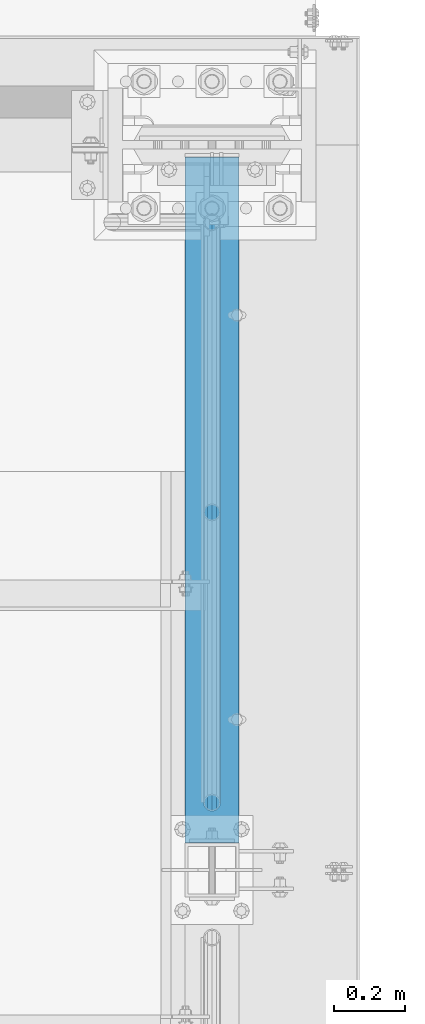
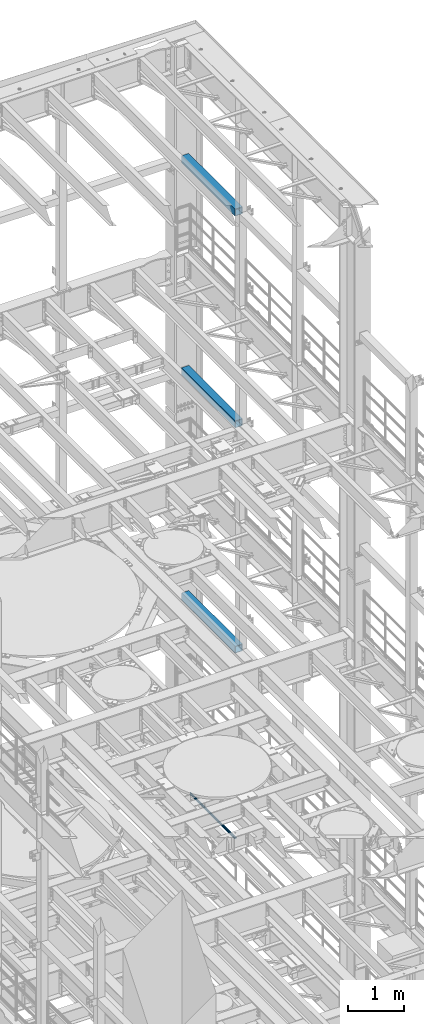
# One storey, part 1079 of 1876: 4 beams, 4 elements without a shape of their own.
"""IFC2X3 building model written with IfcOpenShell, lengths in millimetres."""

from ifc_helpers import new_model, si_unit, frame, origin_with_axes, place, context, subcontext, project, spatial, faceted_brep, material, type_object, element, aggregate, save


model = new_model("IFC2X3")

# Units and contexts
model_context = context("Model", 3, precision=1e-05, world=origin_with_axes())
body_context = subcontext(model_context, "Body", "Model", "MODEL_VIEW")
ifc_project = project(units=[si_unit("LENGTHUNIT", "METRE", prefix="MILLI"), si_unit("AREAUNIT", "SQUARE_METRE"), si_unit("VOLUMEUNIT", "CUBIC_METRE"), si_unit("MASSUNIT", "GRAM", prefix="KILO"), si_unit("TIMEUNIT", "SECOND"), si_unit("PLANEANGLEUNIT", "RADIAN"), si_unit("SOLIDANGLEUNIT", "STERADIAN"), si_unit("THERMODYNAMICTEMPERATUREUNIT", "DEGREE_CELSIUS"), si_unit("LUMINOUSINTENSITYUNIT", "LUMEN")], contexts=[model_context])

# Site, building, storey
site_placement = place(None, origin_with_axes())
site = spatial("IfcSite", under=ifc_project, at=site_placement, CompositionType="ELEMENT")
building_placement = place(site_placement, origin_with_axes())
building = spatial("IfcBuilding", under=site, at=building_placement, Name="Undefined", CompositionType="ELEMENT")
storey_placement = place(building_placement, origin_with_axes())
storey = spatial("IfcBuildingStorey", under=building, at=storey_placement, Name="Undefined", CompositionType="ELEMENT", Elevation=0.0)

# Assembly, beam
assembly_1_placement = place(storey_placement, origin_with_axes())
assembly_1 = element("IfcElementAssembly", 1, at=assembly_1_placement, inside=storey, Name="RAIL", AssemblyPlace="NOTDEFINED", PredefinedType="RIGID_FRAME")
ifc_material_1 = material()
beam_type_1 = type_object("IfcBeamType", Name="PIPE1-1/2SCH40", PredefinedType="NOTDEFINED")
beam_1_placement = place(assembly_1_placement, frame((7619.99999999998, 11848.7825, 6207.125), z_axis=(0.0, 0.0, -1.0), x_axis=(0.0, 1.0, 0.0)))
beam_1 = element("IfcBeam", 2, at=beam_1_placement, type_object=beam_type_1, material=ifc_material_1, Name="RAIL", ObjectType="PIPE1-1/2SCH40", context=body_context, shape_type="Brep", body=[
    faceted_brep([(24.1300000000001, -20.4469999999999, 0.0), (34.3535000000002, -17.7076214311803, 10.2235000000001), (1633.21617856882, -17.7076214311801, 10.2235000000001), (1630.4768, -20.4470000000001, 0.0), (41.8376214311802, -10.2235000000001, 17.7076214311819), (1640.7003, -10.2235000000001, 17.7076214311819), (44.5770000000002, 0.0, 20.4470000000001), (1650.9238, 0.0, 20.4470000000001), (41.8376214311802, 10.2235000000001, 17.7076214311819), (1661.1473, 10.2235000000001, 17.7076214311819), (34.3535000000002, 17.7076214311803, 10.2235000000001), (1668.63142143118, 17.7076214311801, 10.2235000000001), (24.1300000000001, 20.4469999999999, 0.0), (1671.3708, 20.4470000000001, 0.0), (13.9065000000001, 17.7076214311803, -10.2235000000001), (1668.63142143118, 17.7076214311801, -10.2235000000001), (6.42237856882002, 10.2235000000001, -17.7076214311819), (1661.1473, 10.2235000000001, -17.7076214311819), (3.68299999999999, 0.0, -20.4470000000001), (1650.9238, 0.0, -20.4470000000001), (6.42237856882002, -10.2235000000001, -17.7076214311819), (1640.7003, -10.2235000000001, -17.7076214311819), (13.9065000000001, -17.7076214311803, -10.2235000000001), (1633.21617856882, -17.7076214311801, -10.2235000000001), (24.1299999999854, -24.1299999999992, 0.0), (12.0650000000064, -20.8971929933177, -12.0649999999987), (1630.02660700668, -20.8971929933186, -12.0649999999987), (1626.7938, -24.1300000000001, 0.0), (3.23280700668147, -12.0650000000001, -20.8971929933177), (1638.8588, -12.0649999999996, -20.8971929933177), (-1.45519152283669e-11, 0.0, -24.130000000001), (1650.9238, 0.0, -24.130000000001), (3.23280700668147, 12.0650000000001, -20.8971929933177), (1662.9888, 12.0649999999996, -20.8971929933177), (12.0650000000064, 20.8971929933177, -12.0649999999987), (1671.82099299332, 20.8971929933186, -12.0649999999987), (24.1300000000047, 24.1299999999992, 0.0), (1675.0538, 24.1300000000001, 0.0), (36.1949999999997, 20.8971929933184, 12.0649999999987), (1671.82099299332, 20.8971929933186, 12.0649999999987), (45.0271929933187, 12.0650000000001, 20.8971929933177), (1662.9888, 12.0649999999996, 20.8971929933177), (48.2600000000002, 0.0, 24.130000000001), (1650.9238, 0.0, 24.130000000001), (45.0271929933187, -12.0650000000001, 20.8971929933177), (1638.8588, -12.0649999999996, 20.8971929933177), (36.1949999999997, -20.8971929933184, 12.0649999999987), (1630.02660700668, -20.8971929933186, 12.0649999999987)], [[[0, 1, 2, 3]], [[1, 4, 5, 2]], [[4, 6, 7, 5]], [[6, 8, 9, 7]], [[8, 10, 11, 9]], [[10, 12, 13, 11]], [[12, 14, 15, 13]], [[14, 16, 17, 15]], [[16, 18, 19, 17]], [[18, 20, 21, 19]], [[20, 22, 23, 21]], [[22, 0, 3, 23]], [[24, 25, 26, 27]], [[25, 28, 29, 26]], [[28, 30, 31, 29]], [[30, 32, 33, 31]], [[32, 34, 35, 33]], [[34, 36, 37, 35]], [[36, 38, 39, 37]], [[38, 40, 41, 39]], [[40, 42, 43, 41]], [[42, 44, 45, 43]], [[44, 46, 47, 45]], [[46, 24, 27, 47]], [[29, 31, 33, 35, 37, 39, 41, 43, 45, 47, 27, 26], [5, 7, 9, 11, 13, 15, 17, 19, 21, 23, 3, 2]], [[46, 44, 42, 40, 38, 36, 34, 32, 30, 28, 25, 24], [22, 20, 18, 16, 14, 12, 10, 8, 6, 4, 1, 0]]]),
])
aggregate(assembly_1, [beam_1])

assembly_2_placement = place(storey_placement, origin_with_axes())
assembly_2 = element("IfcElementAssembly", 3, at=assembly_2_placement, inside=storey, Name="BEAM", AssemblyPlace="NOTDEFINED", PredefinedType="RIGID_FRAME")
ifc_material_2 = material()
beam_type_2 = type_object("IfcBeamType", Name="HSS6X6X3/8", PredefinedType="NOTDEFINED")
beam_2_placement = place(assembly_2_placement, frame((7620.0, 11684.0, 19958.05), z_axis=(-1.0, 0.0, 0.0), x_axis=(0.0, 1.0, 0.0)))
beam_2 = element("IfcBeam", 4, at=beam_2_placement, type_object=beam_type_2, material=ifc_material_2, Name="BEAM", ObjectType="HSS6X6X3/8", context=body_context, shape_type="Brep", body=[
    faceted_brep([(76.2000000000007, 66.6749999999993, -66.6750000000002), (76.2000000000007, -66.6749999999993, -66.6750000000002), (1997.86875, -66.6749999999993, -66.675), (1997.86875, 66.6749999999993, -66.675), (76.2000000000007, -66.6749999999993, 66.6750000000002), (1997.86875, -66.6749999999993, 66.675), (76.2000000000007, 66.6749999999993, 66.6750000000002), (1997.86875, 66.6749999999993, 66.675), (76.2000000000007, 76.2000000000007, -76.1999999999998), (76.2000000000007, 76.2000000000007, 76.1999999999998), (1997.86875, 76.2000000000007, 76.2), (1997.86875, 76.2000000000007, -76.2), (76.2000000000007, -76.2000000000007, 76.1999999999998), (1997.86875, -76.2000000000007, 76.2), (76.2000000000007, -76.2000000000007, -76.1999999999998), (1997.86875, -76.2000000000007, -76.2)], [[[0, 1, 2, 3]], [[1, 4, 5, 2]], [[4, 6, 7, 5]], [[6, 0, 3, 7]], [[8, 9, 10, 11]], [[9, 12, 13, 10]], [[12, 14, 15, 13]], [[14, 8, 11, 15]], [[13, 15, 11, 10], [5, 7, 3, 2]], [[14, 12, 9, 8], [6, 4, 1, 0]]]),
])
aggregate(assembly_2, [beam_2])

assembly_3_placement = place(storey_placement, origin_with_axes())
assembly_3 = element("IfcElementAssembly", 5, at=assembly_3_placement, inside=storey, Name="BEAM", AssemblyPlace="NOTDEFINED", PredefinedType="RIGID_FRAME")
beam_3_placement = place(assembly_3_placement, frame((7620.0, 11684.0, 15335.25), z_axis=(-1.0, 0.0, 0.0), x_axis=(0.0, 1.0, 0.0)))
beam_3 = element("IfcBeam", 6, at=beam_3_placement, type_object=beam_type_2, material=ifc_material_2, Name="BEAM", ObjectType="HSS6X6X3/8", context=body_context, shape_type="Brep", body=[
    faceted_brep([(76.2000000000007, 66.6749999999993, -66.6750000000002), (76.2000000000007, -66.6749999999993, -66.6750000000002), (1997.86875, -66.6749999999993, -66.675), (1997.86875, 66.6749999999993, -66.675), (76.2000000000007, -66.6749999999993, 66.6750000000002), (1997.86875, -66.6749999999993, 66.675), (76.2000000000007, 66.6749999999993, 66.6750000000002), (1997.86875, 66.6749999999993, 66.675), (76.2000000000007, 76.2000000000007, -76.1999999999998), (76.2000000000007, 76.2000000000007, 76.1999999999998), (1997.86875, 76.2000000000007, 76.2), (1997.86875, 76.2000000000007, -76.2), (76.2000000000007, -76.2000000000007, 76.1999999999998), (1997.86875, -76.2000000000007, 76.2), (76.2000000000007, -76.2000000000007, -76.1999999999998), (1997.86875, -76.2000000000007, -76.2)], [[[0, 1, 2, 3]], [[1, 4, 5, 2]], [[4, 6, 7, 5]], [[6, 0, 3, 7]], [[8, 9, 10, 11]], [[9, 12, 13, 10]], [[12, 14, 15, 13]], [[14, 8, 11, 15]], [[13, 15, 11, 10], [5, 7, 3, 2]], [[14, 12, 9, 8], [6, 4, 1, 0]]]),
])
aggregate(assembly_3, [beam_3])

assembly_4_placement = place(storey_placement, origin_with_axes())
assembly_4 = element("IfcElementAssembly", 7, at=assembly_4_placement, inside=storey, Name="BEAM", AssemblyPlace="NOTDEFINED", PredefinedType="RIGID_FRAME")
beam_4_placement = place(assembly_4_placement, frame((7620.0, 11684.0, 10420.35), z_axis=(-1.0, 0.0, 0.0), x_axis=(0.0, 1.0, 0.0)))
beam_4 = element("IfcBeam", 8, at=beam_4_placement, type_object=beam_type_2, material=ifc_material_2, Name="BEAM", ObjectType="HSS6X6X3/8", context=body_context, shape_type="Brep", body=[
    faceted_brep([(76.2000000000007, 66.6749999999993, -66.6750000000002), (76.2000000000007, -66.6749999999993, -66.6750000000002), (1997.86875, -66.6749999999993, -66.675), (1997.86875, 66.6749999999993, -66.675), (76.2000000000007, -66.6749999999993, 66.6750000000002), (1997.86875, -66.6749999999993, 66.675), (76.2000000000007, 66.6749999999993, 66.6750000000002), (1997.86875, 66.6749999999993, 66.675), (76.2000000000007, 76.2000000000007, -76.1999999999998), (76.2000000000007, 76.2000000000007, 76.1999999999998), (1997.86875, 76.2000000000007, 76.2), (1997.86875, 76.2000000000007, -76.2), (76.2000000000007, -76.2000000000007, 76.1999999999998), (1997.86875, -76.2000000000007, 76.2), (76.2000000000007, -76.2000000000007, -76.1999999999998), (1997.86875, -76.2000000000007, -76.2)], [[[0, 1, 2, 3]], [[1, 4, 5, 2]], [[4, 6, 7, 5]], [[6, 0, 3, 7]], [[8, 9, 10, 11]], [[9, 12, 13, 10]], [[12, 14, 15, 13]], [[14, 8, 11, 15]], [[13, 15, 11, 10], [5, 7, 3, 2]], [[14, 12, 9, 8], [6, 4, 1, 0]]]),
])
aggregate(assembly_4, [beam_4])

save(model, "model.ifc")
